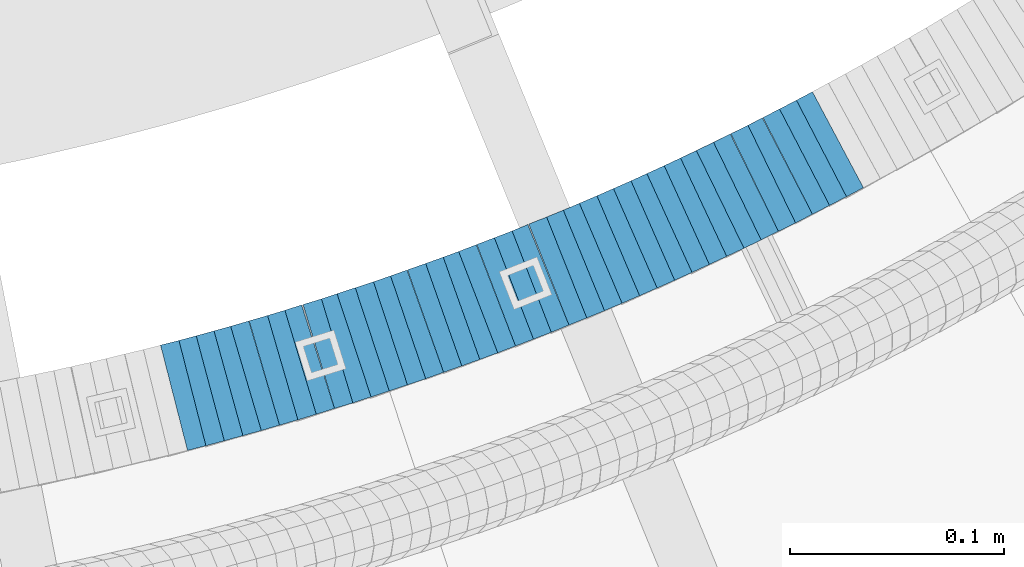
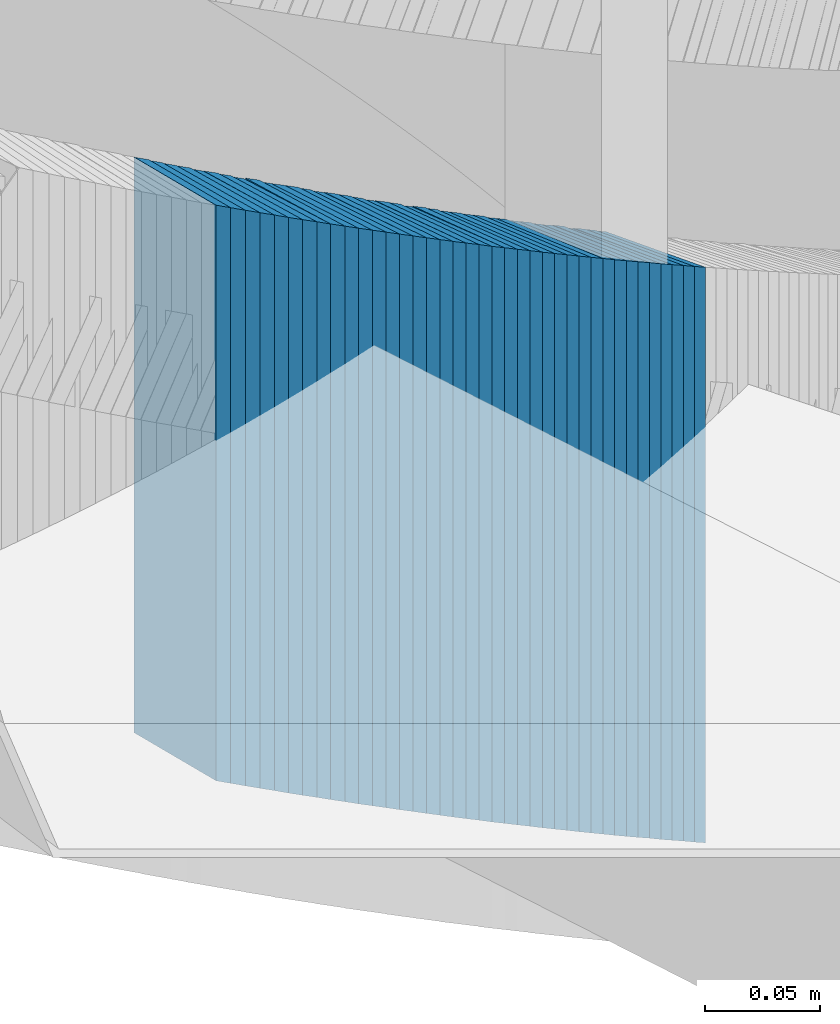
# One storey, part 882 of 975: 38 plates.
"""IFC2X3 building model written with IfcOpenShell, lengths in millimetres."""

from ifc_helpers import new_model, si_unit, frame, origin_with_axes, place, context, subcontext, project, spatial, faceted_brep, material, type_object, element, save


model = new_model("IFC2X3")

# Units and contexts
model_context = context("Model", 3, precision=1e-05, world=origin_with_axes())
body_context = subcontext(model_context, "Body", "Model", "MODEL_VIEW")
ifc_project = project(units=[si_unit("LENGTHUNIT", "METRE", prefix="MILLI"), si_unit("AREAUNIT", "SQUARE_METRE"), si_unit("VOLUMEUNIT", "CUBIC_METRE"), si_unit("MASSUNIT", "GRAM", prefix="KILO"), si_unit("TIMEUNIT", "SECOND"), si_unit("PLANEANGLEUNIT", "RADIAN"), si_unit("SOLIDANGLEUNIT", "STERADIAN"), si_unit("THERMODYNAMICTEMPERATUREUNIT", "DEGREE_CELSIUS"), si_unit("LUMINOUSINTENSITYUNIT", "LUMEN")], contexts=[model_context])

# Site, building, storey
site_placement = place(None, origin_with_axes())
site = spatial("IfcSite", under=ifc_project, at=site_placement, CompositionType="ELEMENT")
building_placement = place(site_placement, origin_with_axes())
building = spatial("IfcBuilding", under=site, at=building_placement, Name="Undefined", CompositionType="ELEMENT")
storey_placement = place(building_placement, origin_with_axes())
storey = spatial("IfcBuildingStorey", under=building, at=storey_placement, Name="Undefined", CompositionType="ELEMENT", Elevation=0.0)

# Plates
ifc_material = material(Name="STEEL/A36")
plate_type = type_object("IfcPlateType", PredefinedType="NOTDEFINED")
plate_1_placement = place(storey_placement, frame((35090.4702663365, 2052.58151833505, 2835.52500005033), z_axis=(-0.968802704444063, -0.247833250113598, 0.0), x_axis=(0.0, 0.0, 1.0)))
element("IfcPlate", 1, at=plate_1_placement, inside=storey, type_object=plate_type, material=ifc_material, Name="WALL", context=body_context, shape_type="Brep", body=[
    faceted_brep([(0.0, -25.3999999999724, -1.81898940354586e-11), (5.69999980926514, -25.4000000000306, 8.88144111634756), (5.69999980926514, 25.4000000000378, 8.88144111629663), (0.0, 25.3999999999869, 1.45519152283669e-11), (310.5, -25.4000000000306, 8.88144111634756), (310.5, 25.4000000000378, 8.88144111629663), (304.799987792969, -25.3999999999724, -1.81898940354586e-11), (304.799987792969, 25.3999999999869, 1.45519152283669e-11)], [[[0, 1, 2, 3]], [[1, 4, 5, 2]], [[4, 6, 7, 5]], [[6, 0, 3, 7]], [[5, 7, 3, 2]], [[6, 4, 1, 0]]]),
])
plate_2_placement = place(storey_placement, frame((35098.8028426942, 2054.81155506075, 2829.82500005033), z_axis=(-0.966048244824465, -0.258361739953055, 0.0), x_axis=(0.0, 0.0, 1.0)))
element("IfcPlate", 2, at=plate_2_placement, inside=storey, type_object=plate_type, material=ifc_material, Name="WALL", context=body_context, shape_type="Brep", body=[
    faceted_brep([(0.0, -25.3999999999724, -1.81898940354586e-11), (5.69999980926514, -25.3999999999469, 8.90224647518698), (5.69999980926514, 25.399999999936, 8.90224647526338), (0.0, 25.3999999999869, 1.45519152283669e-11), (310.5, -25.3999999999469, 8.90224647518698), (310.5, 25.399999999936, 8.90224647526338), (304.799987792969, -25.3999999999724, -1.81898940354586e-11), (304.799987792969, 25.3999999999869, 1.45519152283669e-11)], [[[0, 1, 2, 3]], [[1, 4, 5, 2]], [[4, 6, 7, 5]], [[6, 0, 3, 7]], [[5, 7, 3, 2]], [[6, 4, 1, 0]]]),
])
plate_3_placement = place(storey_placement, frame((35107.3106343344, 2057.15934214526, 2824.02500005033), z_axis=(-0.963992618223753, -0.265928998061726, 0.0), x_axis=(0.0, 0.0, 1.0)))
element("IfcPlate", 3, at=plate_3_placement, inside=storey, type_object=plate_type, material=ifc_material, Name="WALL", context=body_context, shape_type="Brep", body=[
    faceted_brep([(0.0, -25.3999999999724, -1.81898940354586e-11), (5.80000019073486, -25.4000000000997, 9.0210866928719), (5.80000019073486, 25.4000000000451, 9.02108669277732), (0.0, 25.3999999999869, 1.45519152283669e-11), (310.600006103516, -25.4000000000997, 9.0210866928719), (310.600006103516, 25.4000000000451, 9.02108669277732), (304.799987792969, -25.3999999999724, -1.81898940354586e-11), (304.799987792969, 25.3999999999869, 1.45519152283669e-11)], [[[0, 1, 2, 3]], [[1, 4, 5, 2]], [[4, 6, 7, 5]], [[6, 0, 3, 7]], [[5, 7, 3, 2]], [[6, 4, 1, 0]]]),
])
plate_4_placement = place(storey_placement, frame((35115.8377370985, 2059.53911569449, 2818.32500005033), z_axis=(-0.963196301261051, -0.268798968072853, 0.0), x_axis=(0.0, 0.0, 1.0)))
element("IfcPlate", 4, at=plate_4_placement, inside=storey, type_object=plate_type, material=ifc_material, Name="WALL", context=body_context, shape_type="Brep", body=[
    faceted_brep([(0.0, -25.3999999999724, -1.81898940354586e-11), (5.69999980926514, -25.3999999999542, 8.93084526058738), (5.69999980926514, 25.3999999999178, 8.93084526067832), (0.0, 25.3999999999869, 1.45519152283669e-11), (310.5, -25.3999999999542, 8.93084526058738), (310.5, 25.3999999999178, 8.93084526067832), (304.799987792969, -25.3999999999724, -1.81898940354586e-11), (304.799987792969, 25.3999999999869, 1.45519152283669e-11)], [[[0, 1, 2, 3]], [[1, 4, 5, 2]], [[4, 6, 7, 5]], [[6, 0, 3, 7]], [[5, 7, 3, 2]], [[6, 4, 1, 0]]]),
])
plate_5_placement = place(storey_placement, frame((35123.9982062622, 2061.94181338326, 2812.52500005033), z_axis=(-0.959365501603118, -0.282166323883269, 0.0), x_axis=(0.0, 0.0, 1.0)))
element("IfcPlate", 5, at=plate_5_placement, inside=storey, type_object=plate_type, material=ifc_material, Name="WALL", context=body_context, shape_type="Brep", body=[
    faceted_brep([(0.0, -25.3999999999724, -1.81898940354586e-11), (5.80000019073486, -25.4000000000106, 8.86171531681612), (5.80000019073486, 25.4000000000015, 8.86171531675791), (0.0, 25.3999999999869, 1.45519152283669e-11), (310.600006103516, -25.4000000000106, 8.86171531681612), (310.600006103516, 25.4000000000015, 8.86171531675791), (304.799987792969, -25.3999999999724, -1.81898940354586e-11), (304.799987792969, 25.3999999999869, 1.45519152283669e-11)], [[[0, 1, 2, 3]], [[1, 4, 5, 2]], [[4, 6, 7, 5]], [[6, 0, 3, 7]], [[5, 7, 3, 2]], [[6, 4, 1, 0]]]),
])
plate_6_placement = place(storey_placement, frame((35132.6750148723, 2064.46427274853, 2806.82500005033), z_axis=(-0.96024972858431, -0.279142362879158, 0.0), x_axis=(0.0, 0.0, 1.0)))
element("IfcPlate", 6, at=plate_6_placement, inside=storey, type_object=plate_type, material=ifc_material, Name="WALL", context=body_context, shape_type="Brep", body=[
    faceted_brep([(0.0, -25.3999999999724, -1.81898940354586e-11), (5.69999980926514, -25.3999999999105, 8.96270084374919), (5.69999980926514, 25.399999999936, 8.96270084385469), (0.0, 25.3999999999869, 1.45519152283669e-11), (310.5, -25.3999999999105, 8.96270084374919), (310.5, 25.399999999936, 8.96270084385469), (304.799987792969, -25.3999999999724, -1.81898940354586e-11), (304.799987792969, 25.3999999999869, 1.45519152283669e-11)], [[[0, 1, 2, 3]], [[1, 4, 5, 2]], [[4, 6, 7, 5]], [[6, 0, 3, 7]], [[5, 7, 3, 2]], [[6, 4, 1, 0]]]),
])
plate_7_placement = place(storey_placement, frame((35141.014737566, 2066.98709989713, 2801.12500005033), z_axis=(-0.957211427350145, -0.289389501105858, 0.0), x_axis=(0.0, 0.0, 1.0)))
element("IfcPlate", 7, at=plate_7_placement, inside=storey, type_object=plate_type, material=ifc_material, Name="WALL", context=body_context, shape_type="Brep", body=[
    faceted_brep([(0.0, -25.3999999999724, -1.81898940354586e-11), (5.69999980926514, -25.3999999999542, 8.98276138300935), (5.69999980926514, 25.3999999999614, 8.98276138309302), (0.0, 25.3999999999869, 1.45519152283669e-11), (310.5, -25.3999999999542, 8.98276138300935), (310.5, 25.3999999999614, 8.98276138309302), (304.799987792969, -25.3999999999724, -1.81898940354586e-11), (304.799987792969, 25.3999999999869, 1.45519152283669e-11)], [[[0, 1, 2, 3]], [[1, 4, 5, 2]], [[4, 6, 7, 5]], [[6, 0, 3, 7]], [[5, 7, 3, 2]], [[6, 4, 1, 0]]]),
])
plate_8_placement = place(storey_placement, frame((35149.1756142723, 2069.58198194203, 2795.32500005033), z_axis=(-0.953072925181811, -0.302740812057751, 0.0), x_axis=(0.0, 0.0, 1.0)))
element("IfcPlate", 8, at=plate_8_placement, inside=storey, type_object=plate_type, material=ifc_material, Name="WALL", context=body_context, shape_type="Brep", body=[
    faceted_brep([(0.0, -25.3999999999724, -1.81898940354586e-11), (5.80000019073486, -25.3999999999633, 8.91964149466003), (5.80000019073486, 25.3999999999669, 8.91964149481646), (0.0, 25.3999999999869, 1.45519152283669e-11), (310.600006103516, -25.3999999999633, 8.91964149466003), (310.600006103516, 25.3999999999669, 8.91964149481646), (304.799987792969, -25.3999999999724, -1.81898940354586e-11), (304.799987792969, 25.3999999999869, 1.45519152283669e-11)], [[[0, 1, 2, 3]], [[1, 4, 5, 2]], [[4, 6, 7, 5]], [[6, 0, 3, 7]], [[5, 7, 3, 2]], [[6, 4, 1, 0]]]),
])
plate_9_placement = place(storey_placement, frame((35158.1147375751, 2072.28709989723, 2789.62500005033), z_axis=(-0.957211427350145, -0.289389501105858, 0.0), x_axis=(0.0, 0.0, 1.0)))
element("IfcPlate", 9, at=plate_9_placement, inside=storey, type_object=plate_type, material=ifc_material, Name="WALL", context=body_context, shape_type="Brep", body=[
    faceted_brep([(0.0, -25.3999999999724, -1.81898940354586e-11), (5.69999980926514, -25.3999999999542, 8.98276138300935), (5.69999980926514, 25.3999999999614, 8.98276138309302), (0.0, 25.3999999999869, 1.45519152283669e-11), (310.5, -25.3999999999542, 8.98276138300935), (310.5, 25.3999999999614, 8.98276138309302), (304.799987792969, -25.3999999999724, -1.81898940354586e-11), (304.799987792969, 25.3999999999869, 1.45519152283669e-11)], [[[0, 1, 2, 3]], [[1, 4, 5, 2]], [[4, 6, 7, 5]], [[6, 0, 3, 7]], [[5, 7, 3, 2]], [[6, 4, 1, 0]]]),
])
plate_10_placement = place(storey_placement, frame((35166.0182420935, 2074.89871708078, 2783.82500005033), z_axis=(-0.949794781024638, -0.312873575008116, 0.0), x_axis=(0.0, 0.0, 1.0)))
element("IfcPlate", 10, at=plate_10_placement, inside=storey, type_object=plate_type, material=ifc_material, Name="WALL", context=body_context, shape_type="Brep", body=[
    faceted_brep([(0.0, -25.3999999999724, -1.81898940354586e-11), (5.80000019073486, -25.3999999999942, 8.94930171964734), (5.80000019073486, 25.4000000000015, 8.94930171966917), (0.0, 25.3999999999869, 1.45519152283669e-11), (310.600006103516, -25.3999999999942, 8.94930171964734), (310.600006103516, 25.4000000000015, 8.94930171966917), (304.799987792969, -25.3999999999724, -1.81898940354586e-11), (304.799987792969, 25.3999999999869, 1.45519152283669e-11)], [[[0, 1, 2, 3]], [[1, 4, 5, 2]], [[4, 6, 7, 5]], [[6, 0, 3, 7]], [[5, 7, 3, 2]], [[6, 4, 1, 0]]]),
])
for number, where, z_axis, x_axis, name in (
    (11, (35174.5182420961, 2077.69871708069, 2778.12500005033), (-0.949794781024638, -0.312873575008116, 0.0), (0.0, 0.0, 1.0), "WALL"),
    (12, (35183.0182420986, 2080.4987170807, 2772.42500005033), (-0.949794781024638, -0.312873575008116, 0.0), (0.0, 0.0, 1.0), "WALL"),
):
    element("IfcPlate", number, at=place(storey_placement, frame(where, z_axis=z_axis, x_axis=x_axis)), inside=storey, type_object=plate_type, material=ifc_material, Name=name, context=body_context, shape_type="Brep", body=[
        faceted_brep([(0.0, -25.3999999999724, -1.81898940354586e-11), (5.69999980926514, -25.3999999999869, 8.94930171964734), (5.69999980926514, 25.4000000000051, 8.94930171966917), (0.0, 25.3999999999869, 1.45519152283669e-11), (310.5, -25.3999999999869, 8.94930171964734), (310.5, 25.4000000000051, 8.94930171966917), (304.799987792969, -25.3999999999724, -1.81898940354586e-11), (304.799987792969, 25.3999999999869, 1.45519152283669e-11)], [[[0, 1, 2, 3]], [[1, 4, 5, 2]], [[4, 6, 7, 5]], [[6, 0, 3, 7]], [[5, 7, 3, 2]], [[6, 4, 1, 0]]]),
    ])
plate_11_placement = place(storey_placement, frame((35191.2635549558, 2083.31332463556, 2766.62500005033), z_axis=(-0.946432873739402, -0.322900627911091, 0.0), x_axis=(0.0, 0.0, 1.0)))
element("IfcPlate", 13, at=plate_11_placement, inside=storey, type_object=plate_type, material=ifc_material, Name="WALL", context=body_context, shape_type="Brep", body=[
    faceted_brep([(0.0, -25.3999999999724, -1.81898940354586e-11), (5.80000019073486, -25.3999999999432, 8.98109149925949), (5.80000019073486, 25.3999999999651, 8.98109149937954), (0.0, 25.3999999999869, 1.45519152283669e-11), (310.600006103516, -25.3999999999432, 8.98109149925949), (310.600006103516, 25.3999999999651, 8.98109149937954), (304.799987792969, -25.3999999999724, -1.81898940354586e-11), (304.799987792969, 25.3999999999869, 1.45519152283669e-11)], [[[0, 1, 2, 3]], [[1, 4, 5, 2]], [[4, 6, 7, 5]], [[6, 0, 3, 7]], [[5, 7, 3, 2]], [[6, 4, 1, 0]]]),
])
plate_12_placement = place(storey_placement, frame((35199.3222864174, 2086.19417419828, 2760.92500005033), z_axis=(-0.941741911640086, -0.33633639687146, 0.0), x_axis=(0.0, 0.0, 1.0)))
element("IfcPlate", 14, at=plate_12_placement, inside=storey, type_object=plate_type, material=ifc_material, Name="WALL", context=body_context, shape_type="Brep", body=[
    faceted_brep([(0.0, -25.3999999999724, -1.81898940354586e-11), (5.69999980926514, -25.4000000000269, 8.9196414947728), (5.69999980926514, 25.3999999999796, 8.91964149476189), (0.0, 25.3999999999869, 1.45519152283669e-11), (310.5, -25.4000000000269, 8.9196414947728), (310.5, 25.3999999999796, 8.91964149476189), (304.799987792969, -25.3999999999724, -1.81898940354586e-11), (304.799987792969, 25.3999999999869, 1.45519152283669e-11)], [[[0, 1, 2, 3]], [[1, 4, 5, 2]], [[4, 6, 7, 5]], [[6, 0, 3, 7]], [[5, 7, 3, 2]], [[6, 4, 1, 0]]]),
])
plate_13_placement = place(storey_placement, frame((35207.9115999026, 2089.22588411462, 2755.12500005033), z_axis=(-0.942990333545967, -0.332820117839752, 0.0), x_axis=(0.0, 0.0, 1.0)))
element("IfcPlate", 15, at=plate_13_placement, inside=storey, type_object=plate_type, material=ifc_material, Name="WALL", context=body_context, shape_type="Brep", body=[
    faceted_brep([(0.0, -25.3999999999724, -1.81898940354586e-11), (5.80000019073486, -25.400000000016, 9.01387786866326), (5.80000019073486, 25.4000000000306, 9.01387786864143), (0.0, 25.3999999999869, 1.45519152283669e-11), (310.600006103515, -25.400000000016, 9.01387786866326), (310.600006103515, 25.4000000000306, 9.01387786864143), (304.799987792969, -25.3999999999724, -1.81898940354586e-11), (304.799987792969, 25.3999999999869, 1.45519152283669e-11)], [[[0, 1, 2, 3]], [[1, 4, 5, 2]], [[4, 6, 7, 5]], [[6, 0, 3, 7]], [[5, 7, 3, 2]], [[6, 4, 1, 0]]]),
])
plate_14_placement = place(storey_placement, frame((35216.2222864154, 2092.19417419842, 2749.42500005033), z_axis=(-0.941741911640086, -0.33633639687146, 0.0), x_axis=(0.0, 0.0, 1.0)))
element("IfcPlate", 16, at=plate_14_placement, inside=storey, type_object=plate_type, material=ifc_material, Name="WALL", context=body_context, shape_type="Brep", body=[
    faceted_brep([(0.0, -25.3999999999724, -1.81898940354586e-11), (5.69999980926514, -25.4000000000269, 8.9196414947728), (5.69999980926514, 25.3999999999796, 8.91964149476189), (0.0, 25.3999999999869, 1.45519152283669e-11), (310.5, -25.4000000000269, 8.9196414947728), (310.5, 25.3999999999796, 8.91964149476189), (304.799987792969, -25.3999999999724, -1.81898940354586e-11), (304.799987792969, 25.3999999999869, 1.45519152283669e-11)], [[[0, 1, 2, 3]], [[1, 4, 5, 2]], [[4, 6, 7, 5]], [[6, 0, 3, 7]], [[5, 7, 3, 2]], [[6, 4, 1, 0]]]),
])
plate_15_placement = place(storey_placement, frame((35224.3711699993, 2095.20299787824, 2743.62500005033), z_axis=(-0.938152292731597, -0.346222869900947, 0.0), x_axis=(0.0, 0.0, 1.0)))
element("IfcPlate", 17, at=plate_15_placement, inside=storey, type_object=plate_type, material=ifc_material, Name="WALL", context=body_context, shape_type="Brep", body=[
    faceted_brep([(0.0, -25.3999999999724, -1.81898940354586e-11), (5.80000019073486, -25.3999999999942, 8.94930171964734), (5.80000019073486, 25.4000000000015, 8.94930171966917), (0.0, 25.3999999999869, 1.45519152283669e-11), (310.600006103516, -25.3999999999942, 8.94930171964734), (310.600006103516, 25.4000000000015, 8.94930171966917), (304.799987792969, -25.3999999999724, -1.81898940354586e-11), (304.799987792969, 25.3999999999869, 1.45519152283669e-11)], [[[0, 1, 2, 3]], [[1, 4, 5, 2]], [[4, 6, 7, 5]], [[6, 0, 3, 7]], [[5, 7, 3, 2]], [[6, 4, 1, 0]]]),
])
plate_16_placement = place(storey_placement, frame((35232.3280312893, 2098.27354110188, 2737.92500005033), z_axis=(-0.933055569241503, -0.359732268093112, 0.0), x_axis=(0.0, 0.0, 1.0)))
element("IfcPlate", 18, at=plate_16_placement, inside=storey, type_object=plate_type, material=ifc_material, Name="WALL", context=body_context, shape_type="Brep", body=[
    faceted_brep([(0.0, -25.3999999999724, -1.81898940354586e-11), (5.69999980926514, -25.3999999999469, 8.90224647518698), (5.69999980926514, 25.399999999936, 8.90224647526338), (0.0, 25.3999999999869, 1.45519152283669e-11), (310.5, -25.3999999999469, 8.90224647518698), (310.5, 25.399999999936, 8.90224647526338), (304.799987792969, -25.3999999999724, -1.81898940354586e-11), (304.799987792969, 25.3999999999869, 1.45519152283669e-11)], [[[0, 1, 2, 3]], [[1, 4, 5, 2]], [[4, 6, 7, 5]], [[6, 0, 3, 7]], [[5, 7, 3, 2]], [[6, 4, 1, 0]]]),
])
plate_17_placement = place(storey_placement, frame((35240.8229495667, 2101.50991810704, 2732.22500005033), z_axis=(-0.934487734802236, -0.355995327924661, 0.0), x_axis=(0.0, 0.0, 1.0)))
element("IfcPlate", 19, at=plate_17_placement, inside=storey, type_object=plate_type, material=ifc_material, Name="WALL", context=body_context, shape_type="Brep", body=[
    faceted_brep([(0.0, -25.3999999999724, -1.81898940354586e-11), (5.69999980926514, -25.4000000000196, 8.98721313477654), (5.69999980926514, 25.4000000000669, 8.98721313470742), (0.0, 25.3999999999869, 1.45519152283669e-11), (310.5, -25.4000000000196, 8.98721313477654), (310.5, 25.4000000000669, 8.98721313470742), (304.799987792969, -25.3999999999724, -1.81898940354586e-11), (304.799987792969, 25.3999999999869, 1.45519152283669e-11)], [[[0, 1, 2, 3]], [[1, 4, 5, 2]], [[4, 6, 7, 5]], [[6, 0, 3, 7]], [[5, 7, 3, 2]], [[6, 4, 1, 0]]]),
])
plate_18_placement = place(storey_placement, frame((35249.0280312905, 2104.67354110209, 2726.42500005033), z_axis=(-0.933055569241503, -0.359732268093112, 0.0), x_axis=(0.0, 0.0, 1.0)))
element("IfcPlate", 20, at=plate_18_placement, inside=storey, type_object=plate_type, material=ifc_material, Name="WALL", context=body_context, shape_type="Brep", body=[
    faceted_brep([(0.0, -25.3999999999724, -1.81898940354586e-11), (5.80000019073486, -25.3999999999687, 8.90449333185097), (5.80000019073486, 25.3999999999833, 8.90449333192373), (0.0, 25.3999999999869, 1.45519152283669e-11), (310.600006103516, -25.3999999999687, 8.90449333185097), (310.600006103516, 25.3999999999833, 8.90449333192373), (304.799987792969, -25.3999999999724, -1.81898940354586e-11), (304.799987792969, 25.3999999999869, 1.45519152283669e-11)], [[[0, 1, 2, 3]], [[1, 4, 5, 2]], [[4, 6, 7, 5]], [[6, 0, 3, 7]], [[5, 7, 3, 2]], [[6, 4, 1, 0]]]),
])
plate_19_placement = place(storey_placement, frame((35256.8369309992, 2107.87830883209, 2720.72500005033), z_axis=(-0.925369259401997, -0.379066925164674, 0.0), x_axis=(0.0, 0.0, 1.0)))
element("IfcPlate", 21, at=plate_19_placement, inside=storey, type_object=plate_type, material=ifc_material, Name="WALL", context=body_context, shape_type="Brep", body=[
    faceted_brep([(0.0, -25.3999999999724, -1.81898940354586e-11), (5.69999980926514, -25.4000000000124, 8.96939277650017), (5.69999980926514, 25.3999999999869, 8.96939277651836), (0.0, 25.3999999999869, 1.45519152283669e-11), (310.5, -25.4000000000124, 8.96939277650017), (310.5, 25.3999999999869, 8.96939277651836), (304.799987792969, -25.3999999999724, -1.81898940354586e-11), (304.799987792969, 25.3999999999869, 1.45519152283669e-11)], [[[0, 1, 2, 3]], [[1, 4, 5, 2]], [[4, 6, 7, 5]], [[6, 0, 3, 7]], [[5, 7, 3, 2]], [[6, 4, 1, 0]]]),
])
plate_20_placement = place(storey_placement, frame((35265.380957745, 2111.27679848203, 2715.02500005033), z_axis=(-0.929246804682175, -0.369459572873635, 0.0), x_axis=(0.0, 0.0, 1.0)))
element("IfcPlate", 22, at=plate_20_placement, inside=storey, type_object=plate_type, material=ifc_material, Name="WALL", context=body_context, shape_type="Brep", body=[
    faceted_brep([(0.0, -25.3999999999724, -1.81898940354586e-11), (5.69999980926514, -25.3999999999542, 8.93084526058738), (5.69999980926514, 25.3999999999178, 8.93084526067832), (0.0, 25.3999999999869, 1.45519152283669e-11), (310.5, -25.3999999999542, 8.93084526058738), (310.5, 25.3999999999178, 8.93084526067832), (304.799987792969, -25.3999999999724, -1.81898940354586e-11), (304.799987792969, 25.3999999999869, 1.45519152283669e-11)], [[[0, 1, 2, 3]], [[1, 4, 5, 2]], [[4, 6, 7, 5]], [[6, 0, 3, 7]], [[5, 7, 3, 2]], [[6, 4, 1, 0]]]),
])
plate_21_placement = place(storey_placement, frame((35273.4369309952, 2114.57830883195, 2709.32500005033), z_axis=(-0.925369259401997, -0.379066925164674, 0.0), x_axis=(0.0, 0.0, 1.0)))
element("IfcPlate", 23, at=plate_21_placement, inside=storey, type_object=plate_type, material=ifc_material, Name="WALL", context=body_context, shape_type="Brep", body=[
    faceted_brep([(0.0, -25.3999999999724, -1.81898940354586e-11), (5.69999980926514, -25.4000000000124, 8.96939277650017), (5.69999980926514, 25.3999999999869, 8.96939277651836), (0.0, 25.3999999999869, 1.45519152283669e-11), (310.5, -25.4000000000124, 8.96939277650017), (310.5, 25.3999999999869, 8.96939277651836), (304.799987792969, -25.3999999999724, -1.81898940354586e-11), (304.799987792969, 25.3999999999869, 1.45519152283669e-11)], [[[0, 1, 2, 3]], [[1, 4, 5, 2]], [[4, 6, 7, 5]], [[6, 0, 3, 7]], [[5, 7, 3, 2]], [[6, 4, 1, 0]]]),
])
plate_22_placement = place(storey_placement, frame((35281.2940748697, 2117.93492378855, 2703.52500005033), z_axis=(-0.919724178945734, -0.39256519797684, 0.0), x_axis=(0.0, 0.0, 1.0)))
element("IfcPlate", 24, at=plate_22_placement, inside=storey, type_object=plate_type, material=ifc_material, Name="WALL", context=body_context, shape_type="Brep", body=[
    faceted_brep([(0.0, -25.3999999999724, -1.81898940354586e-11), (5.80000019073486, -25.3999999999633, 8.91964149466003), (5.80000019073486, 25.3999999999669, 8.91964149481646), (0.0, 25.3999999999869, 1.45519152283669e-11), (310.600006103516, -25.3999999999633, 8.91964149466003), (310.600006103516, 25.3999999999669, 8.91964149481646), (304.799987792969, -25.3999999999724, -1.81898940354586e-11), (304.799987792969, 25.3999999999869, 1.45519152283669e-11)], [[[0, 1, 2, 3]], [[1, 4, 5, 2]], [[4, 6, 7, 5]], [[6, 0, 3, 7]], [[5, 7, 3, 2]], [[6, 4, 1, 0]]]),
])
plate_23_placement = place(storey_placement, frame((35289.4940748698, 2121.43492378866, 2697.82500005033), z_axis=(-0.919724178945734, -0.39256519797684, 0.0), x_axis=(0.0, 0.0, 1.0)))
element("IfcPlate", 25, at=plate_23_placement, inside=storey, type_object=plate_type, material=ifc_material, Name="WALL", context=body_context, shape_type="Brep", body=[
    faceted_brep([(0.0, -25.3999999999724, -1.81898940354586e-11), (5.69999980926514, -25.4000000000269, 8.9196414947728), (5.69999980926514, 25.3999999999796, 8.91964149476189), (0.0, 25.3999999999869, 1.45519152283669e-11), (310.5, -25.4000000000269, 8.9196414947728), (310.5, 25.3999999999796, 8.91964149476189), (304.799987792969, -25.3999999999724, -1.81898940354586e-11), (304.799987792969, 25.3999999999869, 1.45519152283669e-11)], [[[0, 1, 2, 3]], [[1, 4, 5, 2]], [[4, 6, 7, 5]], [[6, 0, 3, 7]], [[5, 7, 3, 2]], [[6, 4, 1, 0]]]),
])
plate_24_placement = place(storey_placement, frame((35297.4546833208, 2124.93128800954, 2692.12500005033), z_axis=(-0.91564403017333, -0.401990062076094, 0.0), x_axis=(0.0, 0.0, 1.0)))
element("IfcPlate", 26, at=plate_24_placement, inside=storey, type_object=plate_type, material=ifc_material, Name="WALL", context=body_context, shape_type="Brep", body=[
    faceted_brep([(0.0, -25.3999999999724, -1.81898940354586e-11), (5.69999980926514, -25.3999999999105, 8.96270084374919), (5.69999980926514, 25.399999999936, 8.96270084385469), (0.0, 25.3999999999869, 1.45519152283669e-11), (310.5, -25.3999999999105, 8.96270084374919), (310.5, 25.399999999936, 8.96270084385469), (304.799987792969, -25.3999999999724, -1.81898940354586e-11), (304.799987792969, 25.3999999999869, 1.45519152283669e-11)], [[[0, 1, 2, 3]], [[1, 4, 5, 2]], [[4, 6, 7, 5]], [[6, 0, 3, 7]], [[5, 7, 3, 2]], [[6, 4, 1, 0]]]),
])
plate_25_placement = place(storey_placement, frame((35305.6546833265, 2128.53128800991, 2686.32500005033), z_axis=(-0.91564403017333, -0.401990062076094, 0.0), x_axis=(0.0, 0.0, 1.0)))
element("IfcPlate", 27, at=plate_25_placement, inside=storey, type_object=plate_type, material=ifc_material, Name="WALL", context=body_context, shape_type="Brep", body=[
    faceted_brep([(0.0, -25.3999999999724, -1.81898940354586e-11), (5.80000019073486, -25.3999999999105, 8.96270084375283), (5.80000019073486, 25.399999999936, 8.96270084385833), (0.0, 25.3999999999869, 1.45519152283669e-11), (310.600006103516, -25.3999999999105, 8.96270084375283), (310.600006103516, 25.399999999936, 8.96270084385833), (304.799987792969, -25.3999999999724, -1.81898940354586e-11), (304.799987792969, 25.3999999999869, 1.45519152283669e-11)], [[[0, 1, 2, 3]], [[1, 4, 5, 2]], [[4, 6, 7, 5]], [[6, 0, 3, 7]], [[5, 7, 3, 2]], [[6, 4, 1, 0]]]),
])
for number, where, z_axis, x_axis, name in (
    (28, (35313.4116742144, 2132.07766183599, 2680.62500005033), (-0.909595755607489, -0.415494357820706, 0.0), (0.0, 0.0, 1.0), "WALL"),
    (29, (35321.5116742143, 2135.77766183604, 2674.92500005033), (-0.909595755607489, -0.415494357820706, 0.0), (0.0, 0.0, 1.0), "WALL"),
):
    element("IfcPlate", number, at=place(storey_placement, frame(where, z_axis=z_axis, x_axis=x_axis)), inside=storey, type_object=plate_type, material=ifc_material, Name=name, context=body_context, shape_type="Brep", body=[
        faceted_brep([(0.0, -25.3999999999724, -1.81898940354586e-11), (5.69999980926514, -25.4000000000269, 8.91066741947361), (5.69999980926514, 25.4000000000269, 8.91066741941904), (0.0, 25.3999999999869, 1.45519152283669e-11), (310.5, -25.4000000000269, 8.91066741947361), (310.5, 25.4000000000269, 8.91066741941904), (304.799987792969, -25.3999999999724, -1.81898940354586e-11), (304.799987792969, 25.3999999999869, 1.45519152283669e-11)], [[[0, 1, 2, 3]], [[1, 4, 5, 2]], [[4, 6, 7, 5]], [[6, 0, 3, 7]], [[5, 7, 3, 2]], [[6, 4, 1, 0]]]),
    ])
plate_26_placement = place(storey_placement, frame((35329.3773375346, 2139.46917603953, 2669.12500005033), z_axis=(-0.905324661250481, -0.42472021111751, 0.0), x_axis=(0.0, 0.0, 1.0)))
element("IfcPlate", 30, at=plate_26_placement, inside=storey, type_object=plate_type, material=ifc_material, Name="WALL", context=body_context, shape_type="Brep", body=[
    faceted_brep([(0.0, -25.3999999999724, -1.81898940354586e-11), (5.80000019073486, -25.3999999999942, 8.94930171964734), (5.80000019073486, 25.4000000000015, 8.94930171966917), (0.0, 25.3999999999869, 1.45519152283669e-11), (310.600006103516, -25.3999999999942, 8.94930171964734), (310.600006103516, 25.4000000000015, 8.94930171966917), (304.799987792969, -25.3999999999724, -1.81898940354586e-11), (304.799987792969, 25.3999999999869, 1.45519152283669e-11)], [[[0, 1, 2, 3]], [[1, 4, 5, 2]], [[4, 6, 7, 5]], [[6, 0, 3, 7]], [[5, 7, 3, 2]], [[6, 4, 1, 0]]]),
])
plate_27_placement = place(storey_placement, frame((35337.4773375322, 2143.26917603948, 2663.42500005033), z_axis=(-0.905324661250481, -0.42472021111751, 0.0), x_axis=(0.0, 0.0, 1.0)))
element("IfcPlate", 31, at=plate_27_placement, inside=storey, type_object=plate_type, material=ifc_material, Name="WALL", context=body_context, shape_type="Brep", body=[
    faceted_brep([(0.0, -25.3999999999724, -1.81898940354586e-11), (5.69999980926514, -25.3999999999869, 8.94930171964734), (5.69999980926514, 25.4000000000051, 8.94930171966917), (0.0, 25.3999999999869, 1.45519152283669e-11), (310.5, -25.3999999999869, 8.94930171964734), (310.5, 25.4000000000051, 8.94930171966917), (304.799987792969, -25.3999999999724, -1.81898940354586e-11), (304.799987792969, 25.3999999999869, 1.45519152283669e-11)], [[[0, 1, 2, 3]], [[1, 4, 5, 2]], [[4, 6, 7, 5]], [[6, 0, 3, 7]], [[5, 7, 3, 2]], [[6, 4, 1, 0]]]),
])
plate_28_placement = place(storey_placement, frame((35345.1348938147, 2147.00539031718, 2657.72500005033), z_axis=(-0.898876404474688, -0.43820224723141, 0.0), x_axis=(0.0, 0.0, 1.0)))
element("IfcPlate", 32, at=plate_28_placement, inside=storey, type_object=plate_type, material=ifc_material, Name="WALL", context=body_context, shape_type="Brep", body=[
    faceted_brep([(0.0, -25.3999999999724, -1.81898940354586e-11), (5.69999980926514, -25.3999999999469, 8.90224647518698), (5.69999980926514, 25.399999999936, 8.90224647526338), (0.0, 25.3999999999869, 1.45519152283669e-11), (310.5, -25.3999999999469, 8.90224647518698), (310.5, 25.399999999936, 8.90224647526338), (304.799987792969, -25.3999999999724, -1.81898940354586e-11), (304.799987792969, 25.3999999999869, 1.45519152283669e-11)], [[[0, 1, 2, 3]], [[1, 4, 5, 2]], [[4, 6, 7, 5]], [[6, 0, 3, 7]], [[5, 7, 3, 2]], [[6, 4, 1, 0]]]),
])
plate_29_placement = place(storey_placement, frame((35353.1186109723, 2150.94833502107, 2652.02500005033), z_axis=(-0.896630132955879, -0.442780311978213, 0.0), x_axis=(0.0, 0.0, 1.0)))
element("IfcPlate", 33, at=plate_29_placement, inside=storey, type_object=plate_type, material=ifc_material, Name="WALL", context=body_context, shape_type="Brep", body=[
    faceted_brep([(0.0, -25.3999999999724, -1.81898940354586e-11), (5.69999980926514, -25.3999999999901, 9.02718162541714), (5.69999980926514, 25.3999999999951, 9.02718162535166), (0.0, 25.3999999999869, 1.45519152283669e-11), (310.5, -25.3999999999901, 9.02718162541714), (310.5, 25.3999999999951, 9.02718162535166), (304.799987792969, -25.3999999999724, -1.81898940354586e-11), (304.799987792969, 25.3999999999869, 1.45519152283669e-11)], [[[0, 1, 2, 3]], [[1, 4, 5, 2]], [[4, 6, 7, 5]], [[6, 0, 3, 7]], [[5, 7, 3, 2]], [[6, 4, 1, 0]]]),
])
plate_30_placement = place(storey_placement, frame((35361.2348938168, 2154.9053903176, 2646.22500005033), z_axis=(-0.898876404474688, -0.43820224723141, 0.0), x_axis=(0.0, 0.0, 1.0)))
element("IfcPlate", 34, at=plate_30_placement, inside=storey, type_object=plate_type, material=ifc_material, Name="WALL", context=body_context, shape_type="Brep", body=[
    faceted_brep([(0.0, -25.3999999999724, -1.81898940354586e-11), (5.80000019073486, -25.3999999999687, 8.90449333185097), (5.80000019073486, 25.3999999999833, 8.90449333192373), (0.0, 25.3999999999869, 1.45519152283669e-11), (310.600006103516, -25.3999999999687, 8.90449333185097), (310.600006103516, 25.3999999999833, 8.90449333192373), (304.799987792969, -25.3999999999724, -1.81898940354586e-11), (304.799987792969, 25.3999999999869, 1.45519152283669e-11)], [[[0, 1, 2, 3]], [[1, 4, 5, 2]], [[4, 6, 7, 5]], [[6, 0, 3, 7]], [[5, 7, 3, 2]], [[6, 4, 1, 0]]]),
])
plate_31_placement = place(storey_placement, frame((35368.5648458397, 2158.71857400919, 2640.52500005033), z_axis=(-0.887584423832732, -0.460645080913188, 0.0), x_axis=(0.0, 0.0, 1.0)))
element("IfcPlate", 35, at=plate_31_placement, inside=storey, type_object=plate_type, material=ifc_material, Name="WALL", context=body_context, shape_type="Brep", body=[
    faceted_brep([(0.0, -25.3999999999724, -1.81898940354586e-11), (5.69999980926514, -25.3999999999469, 8.90224647518698), (5.69999980926514, 25.399999999936, 8.90224647526338), (0.0, 25.3999999999869, 1.45519152283669e-11), (310.5, -25.3999999999469, 8.90224647518698), (310.5, 25.399999999936, 8.90224647526338), (304.799987792969, -25.3999999999724, -1.81898940354586e-11), (304.799987792969, 25.3999999999869, 1.45519152283669e-11)], [[[0, 1, 2, 3]], [[1, 4, 5, 2]], [[4, 6, 7, 5]], [[6, 0, 3, 7]], [[5, 7, 3, 2]], [[6, 4, 1, 0]]]),
])
plate_32_placement = place(storey_placement, frame((35376.6805248058, 2162.87823420937, 2634.82500005033), z_axis=(-0.889933250612687, -0.456090790801499, 0.0), x_axis=(0.0, 0.0, 1.0)))
element("IfcPlate", 36, at=plate_32_placement, inside=storey, type_object=plate_type, material=ifc_material, Name="WALL", context=body_context, shape_type="Brep", body=[
    faceted_brep([(0.0, -25.3999999999724, -1.81898940354586e-11), (5.69999980926514, -25.4000000000196, 8.98721313477654), (5.69999980926514, 25.4000000000669, 8.98721313470742), (0.0, 25.3999999999869, 1.45519152283669e-11), (310.5, -25.4000000000196, 8.98721313477654), (310.5, 25.4000000000669, 8.98721313470742), (304.799987792969, -25.3999999999724, -1.81898940354586e-11), (304.799987792969, 25.3999999999869, 1.45519152283669e-11)], [[[0, 1, 2, 3]], [[1, 4, 5, 2]], [[4, 6, 7, 5]], [[6, 0, 3, 7]], [[5, 7, 3, 2]], [[6, 4, 1, 0]]]),
])
plate_33_placement = place(storey_placement, frame((35384.4648458387, 2166.91857400935, 2629.02500005033), z_axis=(-0.887584423832732, -0.460645080913188, 0.0), x_axis=(0.0, 0.0, 1.0)))
element("IfcPlate", 37, at=plate_33_placement, inside=storey, type_object=plate_type, material=ifc_material, Name="WALL", context=body_context, shape_type="Brep", body=[
    faceted_brep([(0.0, -25.3999999999724, -1.81898940354586e-11), (5.80000019073486, -25.3999999999687, 8.90449333185097), (5.80000019073486, 25.3999999999833, 8.90449333192373), (0.0, 25.3999999999869, 1.45519152283669e-11), (310.600006103516, -25.3999999999687, 8.90449333185097), (310.600006103516, 25.3999999999833, 8.90449333192373), (304.799987792969, -25.3999999999724, -1.81898940354586e-11), (304.799987792969, 25.3999999999869, 1.45519152283669e-11)], [[[0, 1, 2, 3]], [[1, 4, 5, 2]], [[4, 6, 7, 5]], [[6, 0, 3, 7]], [[5, 7, 3, 2]], [[6, 4, 1, 0]]]),
])
plate_34_placement = place(storey_placement, frame((35392.141769805, 2171.00139217706, 2623.32500005033), z_axis=(-0.882970965859413, -0.469427601925255, 0.0), x_axis=(0.0, 0.0, 1.0)))
element("IfcPlate", 38, at=plate_34_placement, inside=storey, type_object=plate_type, material=ifc_material, Name="WALL", context=body_context, shape_type="Brep", body=[
    faceted_brep([(0.0, -25.3999999999724, -1.81898940354586e-11), (5.69999980926514, -25.3999999999869, 8.94930171964734), (5.69999980926514, 25.4000000000051, 8.94930171966917), (0.0, 25.3999999999869, 1.45519152283669e-11), (310.5, -25.3999999999869, 8.94930171964734), (310.5, 25.4000000000051, 8.94930171966917), (304.799987792969, -25.3999999999724, -1.81898940354586e-11), (304.799987792969, 25.3999999999869, 1.45519152283669e-11)], [[[0, 1, 2, 3]], [[1, 4, 5, 2]], [[4, 6, 7, 5]], [[6, 0, 3, 7]], [[5, 7, 3, 2]], [[6, 4, 1, 0]]]),
])

save(model, "model.ifc")
